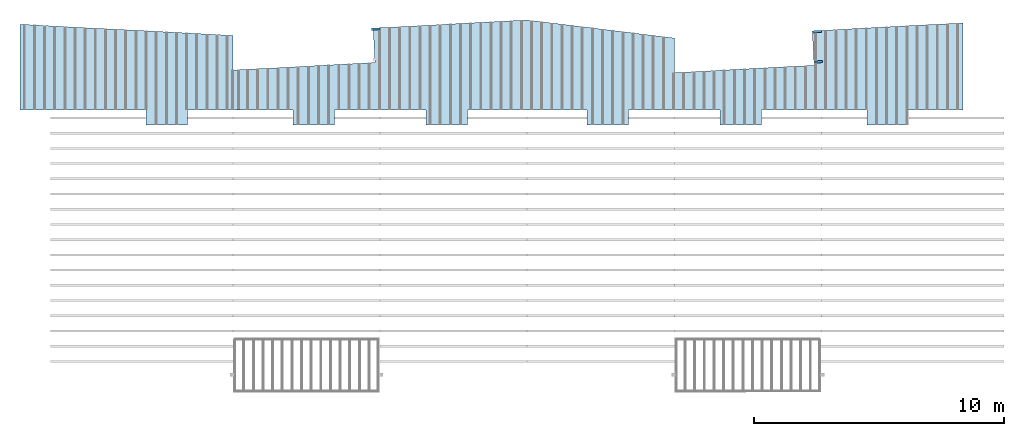
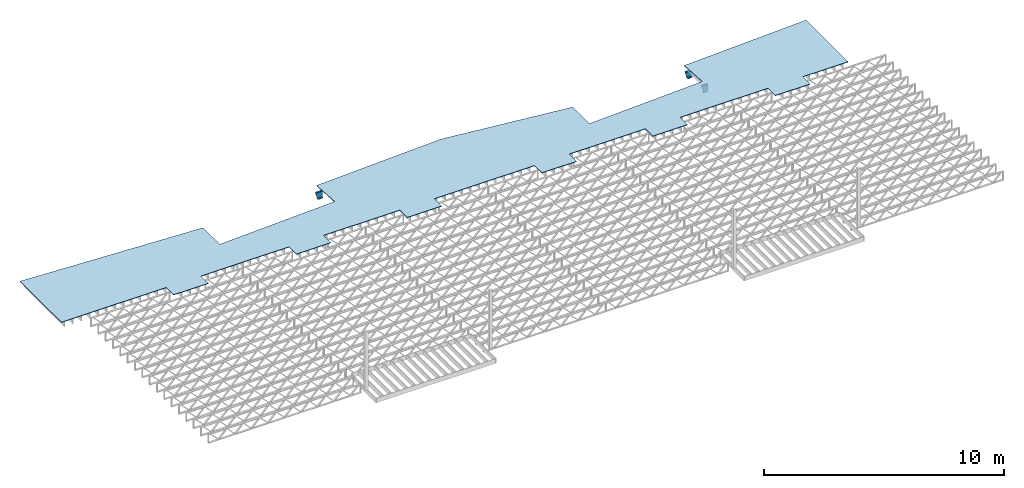
# One storey, part 13 of 13: 3 beams, 1 slab.
"""IFC4 building model written with IfcOpenShell, lengths in feet."""

from ifc_helpers import new_model, entity, si_unit, converted_unit, derived_unit, direction, frame, frame_2d, origin, place, context, subcontext, project, spatial, polyline, circle_curve, parameter, trimmed, segment, composite_curve, outline, extrude, clip, halfspace, source, transform, mapped, material, layer, layer_set, layer_usage, material_profile, profile_set, profile_usage, type_object, type_shapes, element, save


model = new_model("IFC4")

# Units and contexts
model_context_1 = context("Model", 3, precision=0.0001, world=origin(), true_north=direction((6.12303176911189e-17, 1.0)))
model_context_2 = context("Model", 3, precision=0.0001, world=origin(), true_north=direction((6.12303176911189e-17, 1.0)))
body_context = subcontext(model_context_2, "Body", "Model", "MODEL_VIEW")
ifc_project = project(units=[converted_unit("LENGTHUNIT", "FOOT", entity("IfcRatioMeasure", 0.3048), si_unit("LENGTHUNIT", "METRE"), dimensions=[1, 0, 0, 0, 0, 0, 0]), converted_unit("AREAUNIT", "SQUARE FOOT", entity("IfcRatioMeasure", 0.09290304), si_unit("AREAUNIT", "SQUARE_METRE"), dimensions=[2, 0, 0, 0, 0, 0, 0]), converted_unit("VOLUMEUNIT", "CUBIC FOOT", entity("IfcRatioMeasure", 0.028316846592), si_unit("VOLUMEUNIT", "CUBIC_METRE"), dimensions=[3, 0, 0, 0, 0, 0, 0]), converted_unit("PLANEANGLEUNIT", "DEGREE", entity("IfcRatioMeasure", 0.0174532925199433), si_unit("PLANEANGLEUNIT", "RADIAN"), dimensions=[0, 0, 0, 0, 0, 0, 0]), si_unit("MASSUNIT", "GRAM", prefix="KILO"), derived_unit("MASSDENSITYUNIT", [(si_unit("MASSUNIT", "GRAM", prefix="KILO"), 1), (si_unit("LENGTHUNIT", "METRE"), -3)]), derived_unit("MOMENTOFINERTIAUNIT", [(si_unit("LENGTHUNIT", "METRE"), 4)]), si_unit("TIMEUNIT", "SECOND"), si_unit("FREQUENCYUNIT", "HERTZ"), si_unit("THERMODYNAMICTEMPERATUREUNIT", "DEGREE_CELSIUS"), derived_unit("THERMALTRANSMITTANCEUNIT", [(si_unit("MASSUNIT", "GRAM", prefix="KILO"), 1), (si_unit("THERMODYNAMICTEMPERATUREUNIT", "KELVIN"), -1), (si_unit("TIMEUNIT", "SECOND"), -3)]), derived_unit("VOLUMETRICFLOWRATEUNIT", [(si_unit("LENGTHUNIT", "METRE"), 3), (si_unit("TIMEUNIT", "SECOND"), -1)]), si_unit("ELECTRICCURRENTUNIT", "AMPERE"), si_unit("ELECTRICVOLTAGEUNIT", "VOLT"), si_unit("POWERUNIT", "WATT"), si_unit("FORCEUNIT", "NEWTON"), si_unit("ILLUMINANCEUNIT", "LUX"), si_unit("LUMINOUSFLUXUNIT", "LUMEN"), si_unit("LUMINOUSINTENSITYUNIT", "CANDELA"), derived_unit("USERDEFINED", [(si_unit("MASSUNIT", "GRAM", prefix="KILO"), -1), (si_unit("LENGTHUNIT", "METRE"), -2), (si_unit("TIMEUNIT", "SECOND"), 3), (si_unit("LUMINOUSFLUXUNIT", "LUMEN"), 1)]), derived_unit("LINEARVELOCITYUNIT", [(si_unit("LENGTHUNIT", "METRE"), 1), (si_unit("TIMEUNIT", "SECOND"), -1)]), si_unit("PRESSUREUNIT", "PASCAL"), derived_unit("USERDEFINED", [(si_unit("LENGTHUNIT", "METRE"), -2), (si_unit("MASSUNIT", "GRAM", prefix="KILO"), 1), (si_unit("TIMEUNIT", "SECOND"), -2)]), derived_unit("LINEARFORCEUNIT", [(si_unit("MASSUNIT", "GRAM", prefix="KILO"), 1), (si_unit("LENGTHUNIT", "METRE"), 1), (si_unit("TIMEUNIT", "SECOND"), -2), (si_unit("LENGTHUNIT", "METRE"), -1)]), derived_unit("PLANARFORCEUNIT", [(si_unit("MASSUNIT", "GRAM", prefix="KILO"), 1), (si_unit("LENGTHUNIT", "METRE"), 1), (si_unit("TIMEUNIT", "SECOND"), -2), (si_unit("LENGTHUNIT", "METRE"), -2)])], contexts=[model_context_1])

# Site, building, storey
site_placement = place(None, origin())
site = spatial("IfcSite", under=ifc_project, at=site_placement, CompositionType="ELEMENT")
building_placement = place(site_placement, origin())
building = spatial("IfcBuilding", under=site, at=building_placement, CompositionType="ELEMENT")
storey_placement = place(building_placement, frame((0.0, 0.0, 21.46875)))
storey = spatial("IfcBuildingStorey", under=building, at=storey_placement, Name="3RD FLOOR", CompositionType="ELEMENT", Elevation=21.46875)

# Beams
ifc_material_1 = material(Name="STEEL C CHANNEL - HDG - SEE STRUCT", Category="Materials")
ifc_material_profile = material_profile(ifc_material_1, outline(composite_curve([segment(polyline([(-0.625000000000096, -0.136458333333336), (0.625000000000011, -0.136458333333336)]), True, "CONTINUOUS"), segment(polyline([(0.625000000000011, -0.136458333333336), (0.625000000000011, 0.14687499999997)]), True, "CONTINUOUS"), segment(trimmed(circle_curve(frame_2d((0.624999999999954, 0.0927083333333472), x_axis=(0.0, 1.0)), 0.054166666666607), [parameter(0.0)], [parameter(90.0000000000565)], True, "PARAMETER"), True, "CONTINUOUS"), segment(polyline([(0.570833333333347, 0.0927083333333473), (0.539816380436459, -0.1031250000001)]), True, "CONTINUOUS"), segment(polyline([(0.539816380436459, -0.103124999999986), (-0.539816380436541, -0.103124999999985)]), True, "CONTINUOUS"), segment(polyline([(-0.539816380436431, -0.103124999999985), (-0.570833333333319, 0.0927083333333486)]), True, "CONTINUOUS"), segment(trimmed(circle_curve(frame_2d((-0.624999999999922, 0.0927083333333487), x_axis=(1.0, 0.0)), 0.0541666666665973), [parameter(0.0)], [parameter(90.0000000001767)], True, "PARAMETER"), True, "CONTINUOUS"), segment(polyline([(-0.624999999999989, 0.14687499999997), (-0.624999999999986, -0.136458333333336)]), True, "CONTINUOUS")], self_intersect=False)), Name="C15x33.9, TYP. STRINGER")
ifc_profile_set = profile_set([ifc_material_profile], Name="C15x33.9, TYP. STRINGER")
ifc_profile_usage_1 = profile_usage(ifc_profile_set, cardinal=8)
beam_type_1 = type_object("IfcBeamType", Name="C-Channel:C15x33.9, TYP. STRINGER", PredefinedType="BEAM", material=ifc_profile_set)
shared_shape_1 = source(origin(), body_context, "Body", "Clipping", [
    clip(extrude(outline(composite_curve([segment(polyline([(-0.625000000000096, -0.136458333333336), (0.625000000000011, -0.136458333333336)]), True, "CONTINUOUS"), segment(polyline([(0.625000000000011, -0.136458333333336), (0.625000000000011, 0.14687499999997)]), True, "CONTINUOUS"), segment(trimmed(circle_curve(frame_2d((0.624999999999954, 0.0927083333333472), x_axis=(0.0, 1.0)), 0.054166666666607), [parameter(0.0)], [parameter(90.0000000000565)], True, "PARAMETER"), True, "CONTINUOUS"), segment(polyline([(0.570833333333347, 0.0927083333333473), (0.539816380436459, -0.1031250000001)]), True, "CONTINUOUS"), segment(polyline([(0.539816380436459, -0.103124999999986), (-0.539816380436541, -0.103124999999985)]), True, "CONTINUOUS"), segment(polyline([(-0.539816380436431, -0.103124999999985), (-0.570833333333319, 0.0927083333333486)]), True, "CONTINUOUS"), segment(trimmed(circle_curve(frame_2d((-0.624999999999922, 0.0927083333333487), x_axis=(1.0, 0.0)), 0.0541666666665973), [parameter(0.0)], [parameter(90.0000000001767)], True, "PARAMETER"), True, "CONTINUOUS"), segment(polyline([(-0.624999999999989, 0.14687499999997), (-0.624999999999986, -0.136458333333336)]), True, "CONTINUOUS")], self_intersect=False)), frame((-223.549097244249, 969.525938404838, 19.645833333333), z_axis=(0.998629534754577, 0.0523359562428793, 0.0), x_axis=(0.0, 0.0, 1.0)), (0.0, 0.0, 1.0), 1.14955046056795), halfspace(frame((-223.263210744256, 966.417619809988, 19.8353538978054), z_axis=(-0.961136240283351, -0.050371015941545, -0.271440395606476), x_axis=(0.271068395978093, 0.0142060926670286, -0.962455251756153)), False)),
])
type_shapes(beam_type_1, [shared_shape_1])
beam_1_placement = place(storey_placement, frame((0.0, 0.0, -21.46875)))
element("IfcBeam", 1, at=beam_1_placement, inside=storey, type_object=beam_type_1, material=ifc_profile_usage_1, Name="C-Channel:C15x33.9, TYP. STRINGER", ObjectType="C-Channel:C15x33.9, TYP. STRINGER", PredefinedType="BEAM", context=body_context, shape_type="MappedRepresentation", body=[
    mapped(shared_shape_1, transform((0.0, 0.0, 0.0), scale=1.0)),
])
ifc_profile_usage_2 = profile_usage(ifc_profile_set, cardinal=8)
beam_type_2 = type_object("IfcBeamType", Name="C-Channel:C15x33.9, TYP. STRINGER", PredefinedType="BEAM", material=ifc_profile_set)
shared_shape_2 = source(origin(), body_context, "Body", "Clipping", [
    clip(extrude(outline(composite_curve([segment(polyline([(-0.625000000000092, -0.136458333333449), (0.625000000000018, -0.136458333333449)]), True, "CONTINUOUS"), segment(polyline([(0.625000000000014, -0.136458333333449), (0.625000000000018, 0.146874999999857)]), True, "CONTINUOUS"), segment(trimmed(circle_curve(frame_2d((0.624999999999957, 0.0927083333332337), x_axis=(0.0, 1.0)), 0.054166666666607), [parameter(0.0)], [parameter(90.0000000000565)], True, "PARAMETER"), True, "CONTINUOUS"), segment(polyline([(0.570833333333351, 0.0927083333332337), (0.539816380436459, -0.103125000000213)]), True, "CONTINUOUS"), segment(polyline([(0.539816380436463, -0.1031250000001), (-0.539816380436538, -0.103125000000098)]), True, "CONTINUOUS"), segment(polyline([(-0.539816380436427, -0.103125000000098), (-0.570833333333315, 0.0927083333332351)]), True, "CONTINUOUS"), segment(trimmed(circle_curve(frame_2d((-0.624999999999918, 0.0927083333332352), x_axis=(1.0, 0.0)), 0.0541666666665973), [parameter(0.0)], [parameter(90.0000000001767)], True, "PARAMETER"), True, "CONTINUOUS"), segment(polyline([(-0.624999999999986, 0.146874999999857), (-0.624999999999982, -0.136458333333449)]), True, "CONTINUOUS")], self_intersect=False)), frame((-165.549097244249, 969.178537692993, 19.645833333333), z_axis=(0.998629534754577, 0.0523359562428793, 0.0), x_axis=(0.0, 0.0, 1.0)), (0.0, 0.0, 1.0), 1.14955046056795), halfspace(frame((-165.263210744256, 966.070219098144, 19.8353538978054), z_axis=(-0.961136240283351, -0.050371015941545, -0.271440395606476), x_axis=(0.271068395978093, 0.0142060926670286, -0.962455251756153)), False)),
])
type_shapes(beam_type_2, [shared_shape_2])
beam_2_placement = place(storey_placement, frame((0.0, 0.0, -21.46875)))
element("IfcBeam", 2, at=beam_2_placement, inside=storey, type_object=beam_type_2, material=ifc_profile_usage_2, Name="C-Channel:C15x33.9, TYP. STRINGER", ObjectType="C-Channel:C15x33.9, TYP. STRINGER", PredefinedType="BEAM", context=body_context, shape_type="MappedRepresentation", body=[
    mapped(shared_shape_2, transform((0.0, 0.0, 0.0), scale=1.0)),
])
ifc_profile_usage_3 = profile_usage(ifc_profile_set, cardinal=8)
beam_type_3 = type_object("IfcBeamType", Name="C-Channel:C15x33.9, TYP. STRINGER", PredefinedType="BEAM", material=ifc_profile_set)
shared_shape_3 = source(origin(), body_context, "Body", "Clipping", [
    clip(extrude(outline(composite_curve([segment(polyline([(-0.146875000000084, -0.624999999999996), (0.136458333333335, -0.624999999999996)]), True, "CONTINUOUS"), segment(polyline([(0.13645833333322, -0.625000000000028), (0.136458333333335, 0.625000000000004)]), True, "CONTINUOUS"), segment(polyline([(0.136458333333335, 0.625), (-0.146874999999971, 0.625000000000004)]), True, "CONTINUOUS"), segment(trimmed(circle_curve(frame_2d((-0.092708333333348, 0.62499999999994), x_axis=(-1.0, 0.0)), 0.0541666666666108), [parameter(0.0)], [parameter(90.0000000000677)], True, "PARAMETER"), True, "CONTINUOUS"), segment(polyline([(-0.0927083333334615, 0.570833333333333), (0.103124999999984, 0.539816380436445)]), True, "CONTINUOUS"), segment(polyline([(0.10312499999987, 0.539816380436445), (0.103124999999984, -0.539816380436477)]), True, "CONTINUOUS"), segment(polyline([(0.103124999999984, -0.539816380436445), (-0.092708333333348, -0.570833333333333)]), True, "CONTINUOUS"), segment(trimmed(circle_curve(frame_2d((-0.092708333333348, -0.624999999999947), x_axis=(0.0, 1.0)), 0.0541666666666185), [parameter(0.0)], [parameter(90.0000000000715)], True, "PARAMETER"), True, "CONTINUOUS")], self_intersect=False)), frame((-165.340952784941, 965.206904814139, 19.6458333333331), z_axis=(0.998629534754578, 0.0523359562428584, 0.0), x_axis=(0.0523359562428584, -0.998629534754578, 0.0)), (0.0, 0.0, 1.0), 1.08631719611224), halfspace(frame((-165.263210744256, 966.070219098144, 19.8353538978054), z_axis=(-0.961136240283351, -0.050371015941545, -0.271440395606476), x_axis=(0.271068395978093, 0.0142060926670286, -0.962455251756153)), False)),
])
type_shapes(beam_type_3, [shared_shape_3])
beam_3_placement = place(storey_placement, frame((0.0, 0.0, -21.46875)))
element("IfcBeam", 3, at=beam_3_placement, inside=storey, type_object=beam_type_3, material=ifc_profile_usage_3, Name="C-Channel:C15x33.9, TYP. STRINGER", ObjectType="C-Channel:C15x33.9, TYP. STRINGER", PredefinedType="BEAM", context=body_context, shape_type="MappedRepresentation", body=[
    mapped(shared_shape_3, transform((0.0, 0.0, 0.0), scale=1.0)),
])

# Slab
ifc_material_2 = material(Name="COMPOSITE DECKING", Category="Materials")
ifc_layer = layer(ifc_material_2, 0.0833333333333333, Name="COMPOSITE DECKING", Category="Materials")
ifc_layer_set = layer_set([ifc_layer], Name="Floor:floor")
ifc_layer_usage = layer_usage(ifc_layer_set, "AXIS3", "POSITIVE", 0.0)
slab_type = type_object("IfcSlabType", Name="Floor:floor", PredefinedType="FLOOR", material=ifc_layer_set)
slab_placement = place(storey_placement, origin())
element("IfcSlab", 4, at=slab_placement, inside=storey, type_object=slab_type, material=ifc_layer_usage, Name="Floor:floor", ObjectType="Floor:floor", PredefinedType="FLOOR", context=body_context, shape_type="SweptSolid", body=[
    extrude(outline(polyline([(-1.98033034843547, -66.0562902884965), (9.29277395593613, -66.0562902884965), (7.82540166860213, -38.0571591020844), (3.27750707097368, -38.0571591020844), (4.25506133558929, -19.404312559236), (8.79050401399854, -19.6420050380767), (9.85183830875235, 0.609459711505053), (7.47800339388004, 19.9427936210479), (2.93010416499521, 19.9427936210479), (3.8925170201527, 38.306724860383), (8.42797016507154, 38.0692375047629), (9.46687868842082, 57.8927930448347), (-1.98032855120073, 57.8927930448347), (-1.98033034974446, 50.7344599971799), (-3.98032986870351, 50.7344594946763), (-3.98032986870351, 45.276126349964), (-1.98032707903019, 45.276126349964), (-1.98033056383395, 31.4063327962017), (-3.98032986870351, 31.4063332987042), (-3.98032986870351, 25.9427925098845), (-1.98032938330266, 25.9427929988073), (-1.98032644976661, 13.9427933654327), (-3.98032986870373, 13.9427933654327), (-3.98032986870373, 8.48445954404463), (-1.98032660793228, 8.48445954404463), (-1.98033053349741, -7.26554037027961), (-3.98032986870362, -7.26553987179531), (-3.98032986870362, -12.7238741868868), (-1.98032938330198, -12.7238736979644), (-1.98032644976877, -24.7238710863774), (-3.98032986870373, -24.7238710863774), (-3.98032986870373, -30.1874138455924), (-1.98032939924929, -30.1874133430885), (-1.98032591443757, -44.0572053751534), (-3.98032986870373, -44.057205877658), (-3.98032986870373, -49.5207497003005), (-1.98033034843547, -49.5207502028041), (-1.98033034843547, -66.0562902884965)])), frame((-203.680953530366, 960.883931418021, -0.177083333333229), z_axis=(0.0, 0.0, -1.0), x_axis=(0.0, 1.0, 0.0)), (0.0, 0.0, 1.0), 0.0833333333333321),
])

save(model, "model.ifc")
